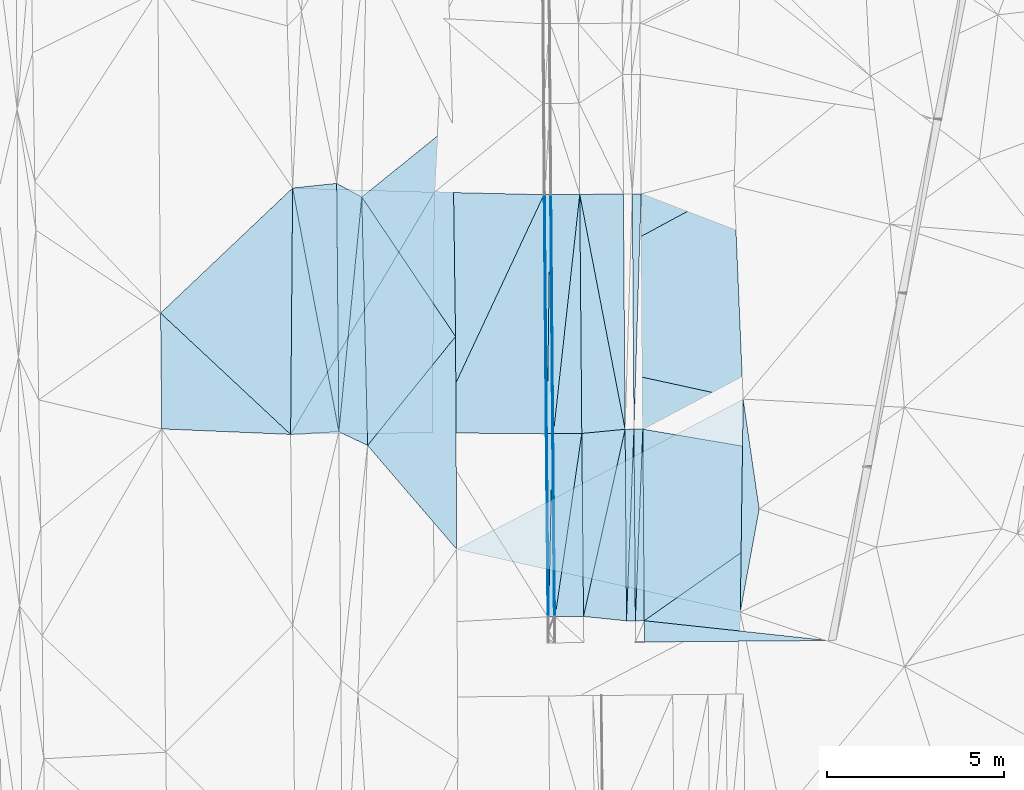
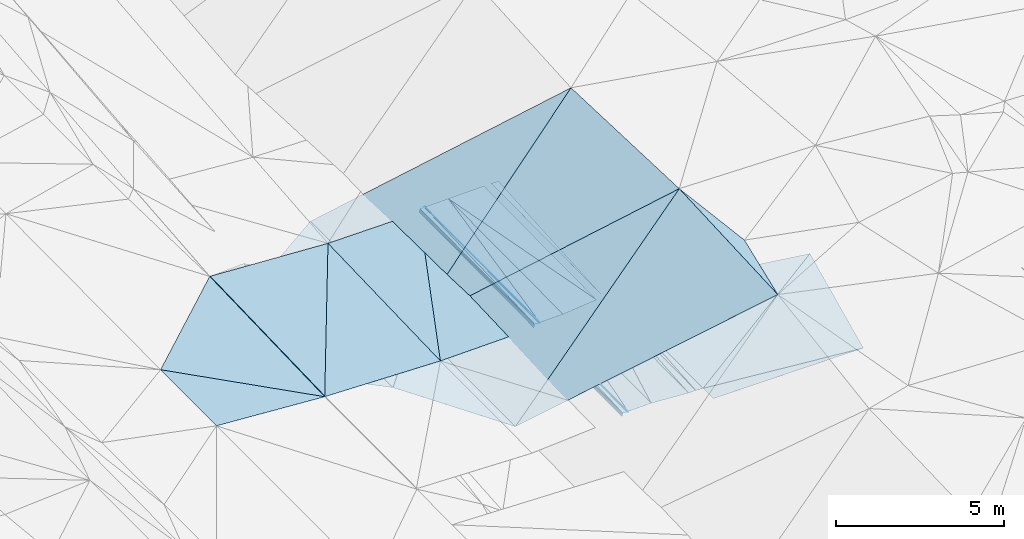
# One storey, part 37 of 275: 46 plates.
"""IFC2X3 building model written with IfcOpenShell, lengths in millimetres."""

from ifc_helpers import new_model, si_unit, frame, origin_with_axes, place, context, subcontext, project, spatial, polyline, outline, extrude, material, type_object, element, save


model = new_model("IFC2X3")

# Units and contexts
model_context = context("Model", 3, precision=1e-05, world=origin_with_axes())
body_context = subcontext(model_context, "Body", "Model", "MODEL_VIEW")
ifc_project = project(units=[si_unit("LENGTHUNIT", "METRE", prefix="MILLI"), si_unit("AREAUNIT", "SQUARE_METRE"), si_unit("VOLUMEUNIT", "CUBIC_METRE"), si_unit("MASSUNIT", "GRAM", prefix="KILO"), si_unit("TIMEUNIT", "SECOND"), si_unit("PLANEANGLEUNIT", "RADIAN"), si_unit("SOLIDANGLEUNIT", "STERADIAN"), si_unit("THERMODYNAMICTEMPERATUREUNIT", "DEGREE_CELSIUS"), si_unit("LUMINOUSINTENSITYUNIT", "LUMEN")], contexts=[model_context])

# Site, building, storey
site_placement = place(None, origin_with_axes())
site = spatial("IfcSite", under=ifc_project, at=site_placement, CompositionType="ELEMENT")
building_placement = place(site_placement, origin_with_axes())
building = spatial("IfcBuilding", under=site, at=building_placement, Name="Undefined", CompositionType="ELEMENT")
storey_placement = place(building_placement, origin_with_axes())
storey = spatial("IfcBuildingStorey", under=building, at=storey_placement, Name="Undefined", CompositionType="ELEMENT", Elevation=0.0)

# Plates
ifc_material = material()
plate_type_1 = type_object("IfcPlateType", PredefinedType="NOTDEFINED")
plate_1_placement = place(storey_placement, frame((-54895.4084070952, 29750.2640162456, 41944.5707269681), z_axis=(-0.0500723807362352, 0.0200544303251957, -0.998544228620714), x_axis=(-0.00717823700979567, 0.999765334400991, 0.0204389100371159)))
element("IfcPlate", 1, at=plate_1_placement, inside=storey, type_object=plate_type_1, material=ifc_material, Name="00_PR", context=body_context, shape_type="SweptSolid", body=[
    extrude(outline(polyline([(0.0, 0.0), (6633.6708984375, -2.11002770811319e-10), (6633.4150390625, 250.312622070313), (0.0, 0.0)])), frame((-8.85201319254618e-08, 2.18876761149539e-07, -0.5000001331573), z_axis=(0.0, 0.0, 1.0), x_axis=(1.0, 0.0, 0.0)), (0.0, 0.0, 1.0), 1.0),
])
plate_2_placement = place(storey_placement, frame((-54856.6384871649, 24350.4041556181, 41820.7377537856), z_axis=(-0.0500876728753474, 0.0225383897221612, -0.998490483687584), x_axis=(-0.00717772900254123, 0.999711397535793, 0.0229260080126891)))
element("IfcPlate", 2, at=plate_2_placement, inside=storey, type_object=plate_type_1, material=ifc_material, Name="00_PR", context=body_context, shape_type="SweptSolid", body=[
    extrude(outline(polyline([(0.0, 0.0), (5401.419921875, -5.98083715885878e-09), (5401.1328125, 250.311676025391), (0.0, 0.0)])), frame((-8.85201319254618e-08, 2.18876761149539e-07, -0.5000001331573), z_axis=(0.0, 0.0, 1.0), x_axis=(1.0, 0.0, 0.0)), (0.0, 0.0, 1.0), 1.0),
])
plate_3_placement = place(storey_placement, frame((-54645.4153229991, 29752.0595880414, 41932.0707538984), z_axis=(-0.0500876728753474, 0.0225383897221612, -0.998490483687584), x_axis=(0.00717789902175713, -0.999711396268906, -0.0229260100259001)))
element("IfcPlate", 3, at=plate_3_placement, inside=storey, type_object=plate_type_1, material=ifc_material, Name="00_PR", context=body_context, shape_type="SweptSolid", body=[
    extrude(outline(polyline([(0.0, 0.0), (5401.41943359375, -2.86672729998827e-09), (5401.1328125, 250.312591552734), (0.0, 0.0)])), frame((-8.85201319254618e-08, 2.18876761149539e-07, -0.5000001331573), z_axis=(0.0, 0.0, 1.0), x_axis=(1.0, 0.0, 0.0)), (0.0, 0.0, 1.0), 1.0),
])
plate_4_placement = place(storey_placement, frame((-54895.3734605082, 29750.2655212708, 41944.5702304905), z_axis=(0.0198256450246044, 0.0230643615691423, -0.99953738250491), x_axis=(0.00717789902175713, -0.999711396268906, -0.0229260100259001)))
element("IfcPlate", 4, at=plate_4_placement, inside=storey, type_object=plate_type_1, material=ifc_material, Name="00_PR", context=body_context, shape_type="SweptSolid", body=[
    extrude(outline(polyline([(0.0, 0.0), (5401.419921875, -5.98083715885878e-09), (5401.5341796875, 250.050415039063), (0.0, 0.0)])), frame((-8.85201319254618e-08, 2.18876761149539e-07, -0.5000001331573), z_axis=(0.0, 0.0, 1.0), x_axis=(1.0, 0.0, 0.0)), (0.0, 0.0, 1.0), 1.0),
])
plate_5_placement = place(storey_placement, frame((-55106.597538753, 24348.6096869643, 41815.7372321746), z_axis=(0.0198256450246044, 0.0230643615691423, -0.99953738250491), x_axis=(-0.00717772900254123, 0.999711397535793, 0.0229260080126891)))
element("IfcPlate", 5, at=plate_5_placement, inside=storey, type_object=plate_type_1, material=ifc_material, Name="00_PR", context=body_context, shape_type="SweptSolid", body=[
    extrude(outline(polyline([(0.0, 0.0), (5401.4189453125, 9.1313268058002e-09), (5401.53466796875, 250.050018310547), (0.0, 0.0)])), frame((-8.85201319254618e-08, 2.18876761149539e-07, -0.5000001331573), z_axis=(0.0, 0.0, 1.0), x_axis=(1.0, 0.0, 0.0)), (0.0, 0.0, 1.0), 1.0),
])
plate_type_2 = type_object("IfcPlateType", PredefinedType="NOTDEFINED")
plate_6_placement = place(storey_placement, frame((-54645.3903405653, 29752.0597822117, 41932.0701304337), z_axis=(-0.000129018325381022, 0.0229256746654247, -0.999737163856284), x_axis=(0.985830827411164, -0.167695548063093, -0.00397276800721903)))
element("IfcPlate", 6, at=plate_6_placement, inside=storey, type_object=plate_type_2, material=ifc_material, Name="00_PR", context=body_context, shape_type="SweptSolid", body=[
    extrude(outline(polyline([(0.0, 0.0), (6307.44091796875, 3.06681613437831e-09), (944.246032714844, 5318.2451171875), (0.0, 0.0)])), frame((-8.85201319254618e-08, 2.18876761149539e-07, -0.5000001331573), z_axis=(0.0, 0.0, 1.0), x_axis=(1.0, 0.0, 0.0)), (0.0, 0.0, 1.0), 1.0),
])
plate_type_3 = type_object("IfcPlateType", PredefinedType="NOTDEFINED")
plate_7_placement = place(storey_placement, frame((-54606.6195060492, 24352.1977344257, 41808.2371014104), z_axis=(-0.000145232154742154, 0.0202303364450008, -0.999795335253643), x_axis=(0.994251223321297, -0.107047497028802, -0.00231047700119528)))
element("IfcPlate", 7, at=plate_7_placement, inside=storey, type_object=plate_type_3, material=ifc_material, Name="00_PR", context=body_context, shape_type="SweptSolid", body=[
    extrude(outline(polyline([(0.0, 0.0), (5217.537109375, -5.2677933126688e-09), (68.5379028320313, 596.1962890625), (0.0, 0.0)])), frame((-8.85201319254618e-08, 2.18876761149539e-07, -0.5000001331573), z_axis=(0.0, 0.0, 1.0), x_axis=(1.0, 0.0, 0.0)), (0.0, 0.0, 1.0), 1.0),
])
plate_type_4 = type_object("IfcPlateType", PredefinedType="NOTDEFINED")
plate_8_placement = place(storey_placement, frame((-48427.3203026964, 28694.3298122455, 41907.0121263178), z_axis=(0.000108681248573426, 0.0225875796306291, -0.999744862169752), x_axis=(-0.198302551947202, -0.979890303884837, -0.0221605560334045)))
element("IfcPlate", 8, at=plate_8_placement, inside=storey, type_object=plate_type_4, material=ifc_material, Name="00_PR", context=body_context, shape_type="SweptSolid", body=[
    extrude(outline(polyline([(0.0, 0.0), (5001.228515625, -2.22644302994013e-09), (5482.37158203125, 5195.30517578125), (0.0, 0.0)])), frame((-8.85201319254618e-08, 2.18876761149539e-07, -0.5000001331573), z_axis=(0.0, 0.0, 1.0), x_axis=(1.0, 0.0, 0.0)), (0.0, 0.0, 1.0), 1.0),
])
plate_type_5 = type_object("IfcPlateType", PredefinedType="NOTDEFINED")
plate_9_placement = place(storey_placement, frame((-57433.1344544477, 36362.7875347337, 41914.3217369555), z_axis=(0.970054360845348, 0.0131957801587972, -0.242529190801695), x_axis=(0.242505601051944, 0.00338357902530367, 0.970144105198509)))
element("IfcPlate", 9, at=plate_9_placement, inside=storey, type_object=plate_type_5, material=ifc_material, Name="00_PR", context=body_context, shape_type="SweptSolid", body=[
    extrude(outline(polyline([(0.0, 0.0), (123.69295501709, -7.27595761418343e-11), (-18.7066040039063, 6740.505859375), (0.0, 0.0)])), frame((-8.85201319254618e-08, 2.18876761149539e-07, -0.5000001331573), z_axis=(0.0, 0.0, 1.0), x_axis=(1.0, 0.0, 0.0)), (0.0, 0.0, 1.0), 1.0),
])
plate_10_placement = place(storey_placement, frame((-57375.8022665797, 29621.3845984136, 41776.7278401148), z_axis=(0.970083354754348, 0.0147495674300355, -0.242323616449527), x_axis=(0.242164143968422, 0.0118048940212785, 0.970163476870361)))
element("IfcPlate", 10, at=plate_10_placement, inside=storey, type_object=plate_type_5, material=ifc_material, Name="00_PR", context=body_context, shape_type="SweptSolid", body=[
    extrude(outline(polyline([(0.0, 0.0), (123.690490722656, -1.12777343019843e-10), (-40.1428527832031, 5157.56005859375), (0.0, 0.0)])), frame((-8.85201319254618e-08, 2.18876761149539e-07, -0.5000001331573), z_axis=(0.0, 0.0, 1.0), x_axis=(1.0, 0.0, 0.0)), (0.0, 0.0, 1.0), 1.0),
])
plate_11_placement = place(storey_placement, frame((-57296.9675207864, 24464.2713309087, 41778.4242810916), z_axis=(0.970303119750049, 0.0147532161955438, -0.241441915199513), x_axis=(-0.241083956011316, -0.0225474160263247, -0.970242310036245)))
element("IfcPlate", 11, at=plate_11_placement, inside=storey, type_object=plate_type_5, material=ifc_material, Name="00_PR", context=body_context, shape_type="SweptSolid", body=[
    extrude(outline(polyline([(0.0, 0.0), (123.68147277832, 2.9831426218152e-10), (-95.6282806396484, 5156.82958984375), (0.0, 0.0)])), frame((-8.85201319254618e-08, 2.18876761149539e-07, -0.5000001331573), z_axis=(0.0, 0.0, 1.0), x_axis=(1.0, 0.0, 0.0)), (0.0, 0.0, 1.0), 1.0),
])
plate_12_placement = place(storey_placement, frame((-57345.8488538652, 29622.8439734198, 41896.7278483205), z_axis=(0.970108864343709, 0.0131959167882542, -0.24231107919754), x_axis=(-0.242164143958002, -0.0118048940251604, -0.970163476872915)))
element("IfcPlate", 12, at=plate_12_placement, inside=storey, type_object=plate_type_5, material=ifc_material, Name="00_PR", context=body_context, shape_type="SweptSolid", body=[
    extrude(outline(polyline([(0.0, 0.0), (123.690490722656, -1.12777343019843e-10), (-75.4959335327148, 6740.10888671875), (0.0, 0.0)])), frame((-8.85201319254618e-08, 2.18876761149539e-07, -0.5000001331573), z_axis=(0.0, 0.0, 1.0), x_axis=(1.0, 0.0, 0.0)), (0.0, 0.0, 1.0), 1.0),
])
plate_type_6 = type_object("IfcPlateType", PredefinedType="NOTDEFINED")
plate_13_placement = place(storey_placement, frame((-57253.6249709212, 36364.2197929239, 42033.9431076846), z_axis=(-0.000137433398031107, 0.0204080235845787, -0.99979172515351), x_axis=(-0.0137480829898779, -0.999697283477655, -0.0204042059757569)))
element("IfcPlate", 13, at=plate_13_placement, inside=storey, type_object=plate_type_6, material=ifc_material, Name="00_PR", context=body_context, shape_type="SweptSolid", body=[
    extrude(outline(polyline([(0.0, 0.0), (6743.41357421875, 1.33222783915699e-08), (3.07201170921326, 149.970291137695), (0.0, 0.0)])), frame((-8.85201319254618e-08, 2.18876761149539e-07, -0.5000001331573), z_axis=(0.0, 0.0, 1.0), x_axis=(1.0, 0.0, 0.0)), (0.0, 0.0, 1.0), 1.0),
])
plate_14_placement = place(storey_placement, frame((-57346.3339198748, 29622.8475791234, 41896.3491080499), z_axis=(-2.34314248828615e-05, 0.0204064566452411, -0.999791766308442), x_axis=(0.0137480829889003, 0.99969728347759, 0.0204042059796114)))
element("IfcPlate", 14, at=plate_14_placement, inside=storey, type_object=plate_type_6, material=ifc_material, Name="00_PR", context=body_context, shape_type="SweptSolid", body=[
    extrude(outline(polyline([(0.0, 0.0), (6743.41357421875, 1.33222783915699e-08), (2.23498868942261, 150.023101806641), (0.0, 0.0)])), frame((-8.85201319254618e-08, 2.18876761149539e-07, -0.5000001331573), z_axis=(0.0, 0.0, 1.0), x_axis=(1.0, 0.0, 0.0)), (0.0, 0.0, 1.0), 1.0),
])
plate_15_placement = place(storey_placement, frame((-57196.2942705991, 29623.0211226267, 41896.3491352206), z_axis=(-2.63265869253447e-05, 0.0229271942118745, -0.999737136987759), x_axis=(-0.019600190991622, -0.999545097466067, -0.0229222739849867)))
element("IfcPlate", 15, at=plate_15_placement, inside=storey, type_object=plate_type_6, material=ifc_material, Name="00_PR", context=body_context, shape_type="SweptSolid", body=[
    extrude(outline(polyline([(0.0, 0.0), (5161.09326171875, 2.97586666420102e-09), (3.1130108833313, 150.007446289063), (0.0, 0.0)])), frame((-8.85201319254618e-08, 2.18876761149539e-07, -0.5000001331573), z_axis=(0.0, 0.0, 1.0), x_axis=(1.0, 0.0, 0.0)), (0.0, 0.0, 1.0), 1.0),
])
plate_16_placement = place(storey_placement, frame((-57297.4525987376, 24464.2754148544, 41778.0451354272), z_axis=(0.00015291009529218, 0.0229236811287797, -0.999737206200714), x_axis=(0.0196001909899472, 0.999545097466061, 0.0229222739866883)))
element("IfcPlate", 16, at=plate_16_placement, inside=storey, type_object=plate_type_6, material=ifc_material, Name="00_PR", context=body_context, shape_type="SweptSolid", body=[
    extrude(outline(polyline([(0.0, 0.0), (5161.09326171875, 2.97586666420102e-09), (1.94216907024384, 150.164596557617), (0.0, 0.0)])), frame((-8.85201319254618e-08, 2.18876761149539e-07, -0.5000001331573), z_axis=(0.0, 0.0, 1.0), x_axis=(1.0, 0.0, 0.0)), (0.0, 0.0, 1.0), 1.0),
])
plate_type_7 = type_object("IfcPlateType", PredefinedType="NOTDEFINED")
plate_17_placement = place(storey_placement, frame((-57223.6165664526, 36364.4578675857, 42034.5432058121), z_axis=(0.0198296849093115, 0.0205713190816245, -0.999591718867078), x_axis=(0.00850252101753427, -0.99975562086186, -0.0204060209610408)))
element("IfcPlate", 17, at=plate_17_placement, inside=storey, type_object=plate_type_7, material=ifc_material, Name="00_PR", context=body_context, shape_type="SweptSolid", body=[
    extrude(outline(polyline([(0.0, 0.0), (6742.8134765625, -6.97764335200191e-09), (-0.00488473894074559, 30.0053634643555), (0.0, 0.0)])), frame((-8.85201319254618e-08, 2.18876761149539e-07, -0.5000001331573), z_axis=(0.0, 0.0, 1.0), x_axis=(1.0, 0.0, 0.0)), (0.0, 0.0, 1.0), 1.0),
])
plate_18_placement = place(storey_placement, frame((-57166.2856756733, 29623.293219365, 41896.949233173), z_axis=(0.0197821144921404, 0.0231056803227607, -0.999537290691569), x_axis=(0.00949658701787016, -0.999692166788818, -0.0229213109592606)))
element("IfcPlate", 18, at=plate_18_placement, inside=storey, type_object=plate_type_7, material=ifc_material, Name="00_PR", context=body_context, shape_type="SweptSolid", body=[
    extrude(outline(polyline([(0.0, 0.0), (5161.31005859375, 4.9622030928731e-09), (0.000789615500252694, 30.0059223175049), (0.0, 0.0)])), frame((-8.85201319254618e-08, 2.18876761149539e-07, -0.5000001331573), z_axis=(0.0, 0.0, 1.0), x_axis=(1.0, 0.0, 0.0)), (0.0, 0.0, 1.0), 1.0),
])
plate_19_placement = place(storey_placement, frame((-57196.2843567241, 29623.0199454779, 41896.3492073408), z_axis=(0.0198061943140049, 0.0205710242482274, -0.999592190659858), x_axis=(-0.00850252101929209, 0.999755620861784, 0.0204060209640744)))
element("IfcPlate", 19, at=plate_19_placement, inside=storey, type_object=plate_type_7, material=ifc_material, Name="00_PR", context=body_context, shape_type="SweptSolid", body=[
    extrude(outline(polyline([(0.0, 0.0), (6742.84765625, -3.44152795150876e-09), (0.0291208140552044, 30.0059070587158), (0.0, 0.0)])), frame((-8.85201319254618e-08, 2.18876761149539e-07, -0.5000001331573), z_axis=(0.0, 0.0, 1.0), x_axis=(1.0, 0.0, 0.0)), (0.0, 0.0, 1.0), 1.0),
])
plate_20_placement = place(storey_placement, frame((-57147.2689878061, 24463.2737848812, 41778.045234851), z_axis=(0.0197624718023815, 0.0231053889510078, -0.999537685987718), x_axis=(-0.00949658701778699, 0.999692166788749, 0.0229213109622704)))
element("IfcPlate", 20, at=plate_20_placement, inside=storey, type_object=plate_type_7, material=ifc_material, Name="00_PR", context=body_context, shape_type="SweptSolid", body=[
    extrude(outline(polyline([(0.0, 0.0), (5161.33642578125, 1.63709046319127e-09), (0.0267784167081118, 30.0055999755859), (0.0, 0.0)])), frame((-8.85201319254618e-08, 2.18876761149539e-07, -0.5000001331573), z_axis=(0.0, 0.0, 1.0), x_axis=(1.0, 0.0, 0.0)), (0.0, 0.0, 1.0), 1.0),
])
plate_type_8 = type_object("IfcPlateType", PredefinedType="NOTDEFINED")
plate_21_placement = place(storey_placement, frame((-60573.7713493108, 29647.2968692294, 41682.639325338), z_axis=(0.0294556231130584, 0.0206475851868098, -0.999352812320541), x_axis=(0.423373744889158, 0.905418206822488, 0.0311856199694956)))
element("IfcPlate", 21, at=plate_21_placement, inside=storey, type_object=plate_type_8, material=ifc_material, Name="00_PR", context=body_context, shape_type="SweptSolid", body=[
    extrude(outline(polyline([(0.0, 0.0), (7417.00830078125, -1.23982317745686e-08), (1333.20068359375, 2907.9248046875), (0.0, 0.0)])), frame((-8.85201319254618e-08, 2.18876761149539e-07, -0.5000001331573), z_axis=(0.0, 0.0, 1.0), x_axis=(1.0, 0.0, 0.0)), (0.0, 0.0, 1.0), 1.0),
])
plate_type_9 = type_object("IfcPlateType", PredefinedType="NOTDEFINED")
plate_22_placement = place(storey_placement, frame((-64574.2855848202, 29603.7668010769, 41809.5003620296), z_axis=(-0.0319130146527098, 0.0206323588611077, -0.999277671752753), x_axis=(0.510579763286938, 0.859829175420949, 0.00144721000004495)))
element("IfcPlate", 22, at=plate_22_placement, inside=storey, type_object=plate_type_9, material=ifc_material, Name="00_PR", context=body_context, shape_type="SweptSolid", body=[
    extrude(outline(polyline([(0.0, 0.0), (7942.87158203125, -3.24507709592581e-09), (2079.81079101563, 3419.97729492188), (0.0, 0.0)])), frame((-8.85201319254618e-08, 2.18876761149539e-07, -0.5000001331573), z_axis=(0.0, 0.0, 1.0), x_axis=(1.0, 0.0, 0.0)), (0.0, 0.0, 1.0), 1.0),
])
plate_type_10 = type_object("IfcPlateType", PredefinedType="NOTDEFINED")
plate_23_placement = place(storey_placement, frame((-60518.8159968476, 36433.279231441, 41820.9953535005), z_axis=(-0.0315165853109351, 0.0203969823452653, -0.999295085528567), x_axis=(-0.510579763289041, -0.859829175419697, -0.00144721000251744)))
element("IfcPlate", 23, at=plate_23_placement, inside=storey, type_object=plate_type_10, material=ifc_material, Name="00_PR", context=body_context, shape_type="SweptSolid", body=[
    extrude(outline(polyline([(0.0, 0.0), (7942.87158203125, -3.24507709592581e-09), (1941.65710449219, 3500.50390625), (0.0, 0.0)])), frame((-8.85201319254618e-08, 2.18876761149539e-07, -0.5000001331573), z_axis=(0.0, 0.0, 1.0), x_axis=(1.0, 0.0, 0.0)), (0.0, 0.0, 1.0), 1.0),
])
plate_type_11 = type_object("IfcPlateType", PredefinedType="NOTDEFINED")
plate_24_placement = place(storey_placement, frame((-55192.9846104297, 36380.5839446059, 42075.1552051376), z_axis=(0.019827502735749, 0.0205777131773347, -0.999591630545022), x_axis=(0.0071782370249891, -0.999765334401105, -0.0204389100262064)))
element("IfcPlate", 24, at=plate_24_placement, inside=storey, type_object=plate_type_11, material=ifc_material, Name="00_PR", context=body_context, shape_type="SweptSolid", body=[
    extrude(outline(polyline([(0.0, 0.0), (6633.671875, 2.05327523872256e-08), (1.43959248065948, 1230.94079589844), (0.0, 0.0)])), frame((-8.85201319254618e-08, 2.18876761149539e-07, -0.5000001331573), z_axis=(0.0, 0.0, 1.0), x_axis=(1.0, 0.0, 0.0)), (0.0, 0.0, 1.0), 1.0),
])
plate_type_12 = type_object("IfcPlateType", PredefinedType="NOTDEFINED")
plate_25_placement = place(storey_placement, frame((-55145.3670981211, 29748.4698762347, 41939.570231511), z_axis=(0.0197544585597547, 0.0230638855470726, -0.99953880292387), x_axis=(0.00717789902175713, -0.999711396268906, -0.0229260100259001)))
element("IfcPlate", 25, at=plate_25_placement, inside=storey, type_object=plate_type_12, material=ifc_material, Name="00_PR", context=body_context, shape_type="SweptSolid", body=[
    extrude(outline(polyline([(0.0, 0.0), (5401.4189453125, 9.1313268058002e-09), (5270.341796875, 1210.0390625), (0.0, 0.0)])), frame((-8.85201319254618e-08, 2.18876761149539e-07, -0.5000001331573), z_axis=(0.0, 0.0, 1.0), x_axis=(1.0, 0.0, 0.0)), (0.0, 0.0, 1.0), 1.0),
])
plate_type_13 = type_object("IfcPlateType", PredefinedType="NOTDEFINED")
plate_26_placement = place(storey_placement, frame((-56423.6413719435, 36370.8112537786, 42050.5432053524), z_axis=(0.0198060953423537, 0.0205738530104772, -0.999592134402624), x_axis=(0.00850248800260614, -0.999755565497945, -0.0204087469887167)))
element("IfcPlate", 26, at=plate_26_placement, inside=storey, type_object=plate_type_13, material=ifc_material, Name="00_PR", context=body_context, shape_type="SweptSolid", body=[
    extrude(outline(polyline([(0.0, 0.0), (6741.9130859375, 2.04454408958554e-09), (6742.6904296875, 800.159851074219), (0.0, 0.0)])), frame((-8.85201319254618e-08, 2.18876761149539e-07, -0.5000001331573), z_axis=(0.0, 0.0, 1.0), x_axis=(1.0, 0.0, 0.0)), (0.0, 0.0, 1.0), 1.0),
])
plate_27_placement = place(storey_placement, frame((-56366.318358162, 29630.5473365314, 41912.949232907), z_axis=(0.0197622458418474, 0.0231085657826838, -0.999537617014364), x_axis=(0.00949656499882243, -0.99969209669469, -0.0229243769686051)))
element("IfcPlate", 27, at=plate_27_placement, inside=storey, type_object=plate_type_13, material=ifc_material, Name="00_PR", context=body_context, shape_type="SweptSolid", body=[
    extrude(outline(polyline([(0.0, 0.0), (5160.6201171875, -3.58704710379243e-09), (5161.33203125, 800.159790039063), (0.0, 0.0)])), frame((-8.85201319254618e-08, 2.18876761149539e-07, -0.5000001331573), z_axis=(0.0, 0.0, 1.0), x_axis=(1.0, 0.0, 0.0)), (0.0, 0.0, 1.0), 1.0),
])
plate_28_placement = place(storey_placement, frame((-57166.2856519693, 29623.2919521182, 41896.9492060201), z_axis=(0.0198296849093115, 0.0205713190816245, -0.999591718867078), x_axis=(-0.00850252101929209, 0.999755620861784, 0.0204060209640744)))
element("IfcPlate", 28, at=plate_28_placement, inside=storey, type_object=plate_type_13, material=ifc_material, Name="00_PR", context=body_context, shape_type="SweptSolid", body=[
    extrude(outline(polyline([(0.0, 0.0), (6742.8134765625, -6.97764335200191e-09), (6742.6904296875, 800.160400390625), (0.0, 0.0)])), frame((-8.85201319254618e-08, 2.18876761149539e-07, -0.5000001331573), z_axis=(0.0, 0.0, 1.0), x_axis=(1.0, 0.0, 0.0)), (0.0, 0.0, 1.0), 1.0),
])
plate_29_placement = place(storey_placement, frame((-57117.2708424667, 24463.5717848462, 41778.6452333011), z_axis=(0.0197821144921404, 0.0231056803227607, -0.999537290691569), x_axis=(-0.00949658701778699, 0.999692166788749, 0.0229213109622704)))
element("IfcPlate", 29, at=plate_29_placement, inside=storey, type_object=plate_type_13, material=ifc_material, Name="00_PR", context=body_context, shape_type="SweptSolid", body=[
    extrude(outline(polyline([(0.0, 0.0), (5161.31005859375, 4.9622030928731e-09), (5161.33203125, 800.160217285156), (0.0, 0.0)])), frame((-8.85201319254618e-08, 2.18876761149539e-07, -0.5000001331573), z_axis=(0.0, 0.0, 1.0), x_axis=(1.0, 0.0, 0.0)), (0.0, 0.0, 1.0), 1.0),
])
plate_type_14 = type_object("IfcPlateType", PredefinedType="NOTDEFINED")
plate_30_placement = place(storey_placement, frame((-56366.3183356965, 29630.5460691692, 41912.9492055878), z_axis=(0.0198075215973235, 0.0205738645548118, -0.999592105903929), x_axis=(-0.00850248800490916, 0.999755565498, 0.0204087469850903)))
element("IfcPlate", 30, at=plate_30_placement, inside=storey, type_object=plate_type_14, material=ifc_material, Name="00_PR", context=body_context, shape_type="SweptSolid", body=[
    extrude(outline(polyline([(0.0, 0.0), (6741.9130859375, 2.04454408958554e-09), (108.05591583252, 1222.15393066406), (0.0, 0.0)])), frame((-8.85201319254618e-08, 2.18876761149539e-07, -0.5000001331573), z_axis=(0.0, 0.0, 1.0), x_axis=(1.0, 0.0, 0.0)), (0.0, 0.0, 1.0), 1.0),
])
plate_type_15 = type_object("IfcPlateType", PredefinedType="NOTDEFINED")
plate_31_placement = place(storey_placement, frame((-56317.3102920617, 24471.5161477881, 41794.6452307876), z_axis=(0.0195617873476278, 0.0231067529108341, -0.999541602158551), x_axis=(-0.00949656499819359, 0.999692096694775, 0.0229243769651296)))
element("IfcPlate", 31, at=plate_31_placement, inside=storey, type_object=plate_type_15, material=ifc_material, Name="00_PR", context=body_context, shape_type="SweptSolid", body=[
    extrude(outline(polyline([(0.0, 0.0), (5160.6201171875, -3.58704710379243e-09), (5267.52197265625, 1222.25549316406), (0.0, 0.0)])), frame((-8.85201319254618e-08, 2.18876761149539e-07, -0.5000001331573), z_axis=(0.0, 0.0, 1.0), x_axis=(1.0, 0.0, 0.0)), (0.0, 0.0, 1.0), 1.0),
])
plate_type_16 = type_object("IfcPlateType", PredefinedType="NOTDEFINED")
plate_32_placement = place(storey_placement, frame((-57433.6041983802, 36362.7910009887, 41913.9433365491), z_axis=(0.0305669138235757, 0.0201271605159665, -0.999330056182074), x_axis=(-0.423373744903151, -0.905418206850314, -0.0311856189716123)))
element("IfcPlate", 32, at=plate_32_placement, inside=storey, type_object=plate_type_16, material=ifc_material, Name="00_PR", context=body_context, shape_type="SweptSolid", body=[
    extrude(outline(polyline([(0.0, 0.0), (7417.00830078125, -1.23982317745686e-08), (1245.26196289063, 2825.1142578125), (0.0, 0.0)])), frame((-8.85201319254618e-08, 2.18876761149539e-07, -0.5000001331573), z_axis=(0.0, 0.0, 1.0), x_axis=(1.0, 0.0, 0.0)), (0.0, 0.0, 1.0), 1.0),
])
plate_type_17 = type_object("IfcPlateType", PredefinedType="NOTDEFINED")
plate_33_placement = place(storey_placement, frame((-51898.4024897921, 24594.4398376857, 44120.5035362828), z_axis=(-0.114787666962505, 0.0309803187056542, -0.9929068492896), x_axis=(0.0134066323516429, 0.999470868069656, 0.029635217041154)))
element("IfcPlate", 33, at=plate_33_placement, inside=storey, type_object=plate_type_17, material=ifc_material, Name="00", context=body_context, shape_type="SweptSolid", body=[
    extrude(outline(polyline([(0.0, 0.0), (6006.3671875, 5.26051735505462e-09), (2911.04443359375, 497.379730224609), (0.0, 0.0)])), frame((-8.85201319254618e-08, 2.18876761149539e-07, -0.5000001331573), z_axis=(0.0, 0.0, 1.0), x_axis=(1.0, 0.0, 0.0)), (0.0, 0.0, 1.0), 1.0),
])
plate_type_18 = type_object("IfcPlateType", PredefinedType="NOTDEFINED")
plate_34_placement = place(storey_placement, frame((-63213.772481078, 29679.3772558111, 41764.513744858), z_axis=(-0.232296113468906, 0.0173904518013238, -0.972489633802534), x_axis=(-0.0088541374933108, 0.999760911659468, 0.0199930929842949)))
element("IfcPlate", 34, at=plate_34_placement, inside=storey, type_object=plate_type_18, material=ifc_material, Name="00", context=body_context, shape_type="SweptSolid", body=[
    extrude(outline(polyline([(0.0, 0.0), (7002.41796875, -6.66477717459202e-09), (6605.90869140625, 724.180297851563), (0.0, 0.0)])), frame((-8.85201319254618e-08, 2.18876761149539e-07, -0.5000001331573), z_axis=(0.0, 0.0, 1.0), x_axis=(1.0, 0.0, 0.0)), (0.0, 0.0, 1.0), 1.0),
])
plate_type_19 = type_object("IfcPlateType", PredefinedType="NOTDEFINED")
plate_35_placement = place(storey_placement, frame((-59924.4650161632, 32362.3789614874, 41130.5362433382), z_axis=(0.372835690124525, 0.0272297145207694, -0.927497757849843), x_axis=(-0.0137496555623442, 0.9996217043267, 0.0238200590028775)))
element("IfcPlate", 35, at=plate_35_placement, inside=storey, type_object=plate_type_19, material=ifc_material, Name="00", context=body_context, shape_type="SweptSolid", body=[
    extrude(outline(polyline([(0.0, 0.0), (6003.34375, -3.39059624820948e-09), (4207.67578125, 8525.962890625), (0.0, 0.0)])), frame((-8.85201319254618e-08, 2.18876761149539e-07, -0.5000001331573), z_axis=(0.0, 0.0, 1.0), x_axis=(1.0, 0.0, 0.0)), (0.0, 0.0, 1.0), 1.0),
])
plate_type_20 = type_object("IfcPlateType", PredefinedType="NOTDEFINED")
plate_36_placement = place(storey_placement, frame((-62567.9179674236, 36293.3050445465, 41728.5130669872), z_axis=(-0.226557531196561, 0.0168226604904226, -0.973852495582438), x_axis=(0.0233621655435943, -0.999469315164357, -0.0227001600435862)))
element("IfcPlate", 36, at=plate_36_placement, inside=storey, type_object=plate_type_20, material=ifc_material, Name="00", context=body_context, shape_type="SweptSolid", body=[
    extrude(outline(polyline([(0.0, 0.0), (7004.35595703125, 3.11410985887051e-09), (6594.5126953125, 821.5048828125), (0.0, 0.0)])), frame((-8.85201319254618e-08, 2.18876761149539e-07, -0.5000001331573), z_axis=(0.0, 0.0, 1.0), x_axis=(1.0, 0.0, 0.0)), (0.0, 0.0, 1.0), 1.0),
])
plate_type_21 = type_object("IfcPlateType", PredefinedType="NOTDEFINED")
plate_37_placement = place(storey_placement, frame((-60007.2909177041, 38363.4482532324, 41273.5093221384), z_axis=(-0.191155981866452, 0.0207551044603268, -0.981340214316887), x_axis=(0.0137496555616393, -0.999621704326797, -0.0238200589992076)))
element("IfcPlate", 37, at=plate_37_placement, inside=storey, type_object=plate_type_21, material=ifc_material, Name="00", context=body_context, shape_type="SweptSolid", body=[
    extrude(outline(polyline([(0.0, 0.0), (6003.34375, -3.39059624820948e-09), (2023.3125, 2637.31616210938), (0.0, 0.0)])), frame((-8.85201319254618e-08, 2.18876761149539e-07, -0.5000001331573), z_axis=(0.0, 0.0, 1.0), x_axis=(1.0, 0.0, 0.0)), (0.0, 0.0, 1.0), 1.0),
])
plate_type_22 = type_object("IfcPlateType", PredefinedType="NOTDEFINED")
plate_38_placement = place(storey_placement, frame((-68240.0858667427, 33023.5491804737, 41999.5003570351), z_axis=(-0.032113333044828, 0.0210945146330983, -0.999261605033009), x_axis=(0.73069297742833, -0.681654952569259, -0.037872131900954)))
element("IfcPlate", 38, at=plate_38_placement, inside=storey, type_object=plate_type_22, material=ifc_material, Name="00", context=body_context, shape_type="SweptSolid", body=[
    extrude(outline(polyline([(0.0, 0.0), (5016.88134765625, 5.84259396418929e-09), (2252.7939453125, 2365.14697265625), (0.0, 0.0)])), frame((-8.85201319254618e-08, 2.18876761149539e-07, -0.5000001331573), z_axis=(0.0, 0.0, 1.0), x_axis=(1.0, 0.0, 0.0)), (0.0, 0.0, 1.0), 1.0),
])
plate_type_23 = type_object("IfcPlateType", PredefinedType="NOTDEFINED")
plate_39_placement = place(storey_placement, frame((-62567.9024480432, 36293.3054833461, 41728.5097229522), z_axis=(-0.195518473074691, 0.017700079356071, -0.9805402765197), x_axis=(0.553595079682288, -0.823313675015829, -0.125248074969202)))
element("IfcPlate", 39, at=plate_39_placement, inside=storey, type_object=plate_type_23, material=ifc_material, Name="00", context=body_context, shape_type="SweptSolid", body=[
    extrude(outline(polyline([(0.0, 0.0), (4774.5244140625, -2.83762346953154e-10), (5874.224609375, 3815.0341796875), (0.0, 0.0)])), frame((-8.85201319254618e-08, 2.18876761149539e-07, -0.5000001331573), z_axis=(0.0, 0.0, 1.0), x_axis=(1.0, 0.0, 0.0)), (0.0, 0.0, 1.0), 1.0),
])
plate_type_24 = type_object("IfcPlateType", PredefinedType="NOTDEFINED")
plate_40_placement = place(storey_placement, frame((-64518.0073399526, 36549.6523368873, 41949.5004542252), z_axis=(-0.0382513769033427, 0.0196406145129394, -0.999075111503911), x_axis=(0.993885881095871, 0.104378165551919, -0.0360007488019535)))
element("IfcPlate", 40, at=plate_40_placement, inside=storey, type_object=plate_type_24, material=ifc_material, Name="00", context=body_context, shape_type="SweptSolid", body=[
    extrude(outline(polyline([(0.0, 0.0), (1249.97399902344, -1.09139364212751e-09), (585.910583496094, 6970.859375), (0.0, 0.0)])), frame((-8.85201319254618e-08, 2.18876761149539e-07, -0.5000001331573), z_axis=(0.0, 0.0, 1.0), x_axis=(1.0, 0.0, 0.0)), (0.0, 0.0, 1.0), 1.0),
])
plate_type_25 = type_object("IfcPlateType", PredefinedType="NOTDEFINED")
plate_41_placement = place(storey_placement, frame((-63213.6734161029, 29679.3787625358, 41764.5003879549), z_axis=(-0.0341816967635243, 0.0204168035910726, -0.999207068498562), x_axis=(-0.997915488761257, -0.0554561845190906, 0.0330043768152871)))
element("IfcPlate", 41, at=plate_41_placement, inside=storey, type_object=plate_type_25, material=ifc_material, Name="00", context=body_context, shape_type="SweptSolid", body=[
    extrude(outline(polyline([(0.0, 0.0), (1363.45556640625, -3.04862624034286e-09), (926.719604492188, 6933.7841796875), (0.0, 0.0)])), frame((-8.85201319254618e-08, 2.18876761149539e-07, -0.5000001331573), z_axis=(0.0, 0.0, 1.0), x_axis=(1.0, 0.0, 0.0)), (0.0, 0.0, 1.0), 1.0),
])
plate_type_26 = type_object("IfcPlateType", PredefinedType="NOTDEFINED")
plate_42_placement = place(storey_placement, frame((-64518.0045877333, 36549.6527186737, 41949.5003633032), z_axis=(-0.0327551052870301, 0.0204062114104521, -0.999255067344423), x_axis=(-0.00810094444361597, -0.999764126881034, -0.0201510620296958)))
element("IfcPlate", 42, at=plate_42_placement, inside=storey, type_object=plate_type_26, material=ifc_material, Name="00", context=body_context, shape_type="SweptSolid", body=[
    extrude(outline(polyline([(0.0, 0.0), (6947.52490234375, -1.17142917588353e-08), (3554.4169921875, 3695.3916015625), (0.0, 0.0)])), frame((-8.85201319254618e-08, 2.18876761149539e-07, -0.5000001331573), z_axis=(0.0, 0.0, 1.0), x_axis=(1.0, 0.0, 0.0)), (0.0, 0.0, 1.0), 1.0),
])
plate_type_27 = type_object("IfcPlateType", PredefinedType="NOTDEFINED")
plate_43_placement = place(storey_placement, frame((-59924.7461383784, 32362.3716399633, 41130.509081883), z_axis=(-0.189414600844779, 0.0125872403167288, -0.981816515632133), x_axis=(0.00528217149556032, -0.999890298151527, -0.0138380029896693)))
element("IfcPlate", 43, at=plate_43_placement, inside=storey, type_object=plate_type_27, material=ifc_material, Name="00", context=body_context, shape_type="SweptSolid", body=[
    extrude(outline(polyline([(0.0, 0.0), (5997.9755859375, 1.73167791217566e-09), (3050.19873046875, 2541.67553710938), (0.0, 0.0)])), frame((-8.85201319254618e-08, 2.18876761149539e-07, -0.5000001331573), z_axis=(0.0, 0.0, 1.0), x_axis=(1.0, 0.0, 0.0)), (0.0, 0.0, 1.0), 1.0),
])
plate_type_28 = type_object("IfcPlateType", PredefinedType="NOTDEFINED")
plate_44_placement = place(storey_placement, frame((-59892.7857277048, 26365.0553304786, 41047.5348877972), z_axis=(0.366732478170775, 0.0148109972018887, -0.930208537811069), x_axis=(-0.00528217156019506, 0.99989029815097, 0.0138380030052257)))
element("IfcPlate", 44, at=plate_44_placement, inside=storey, type_object=plate_type_28, material=ifc_material, Name="00", context=body_context, shape_type="SweptSolid", body=[
    extrude(outline(polyline([(0.0, 0.0), (5997.9755859375, 1.73167791217566e-09), (4234.4345703125, 8704.091796875), (0.0, 0.0)])), frame((-8.85201319254618e-08, 2.18876761149539e-07, -0.5000001331573), z_axis=(0.0, 0.0, 1.0), x_axis=(1.0, 0.0, 0.0)), (0.0, 0.0, 1.0), 1.0),
])
plate_type_29 = type_object("IfcPlateType", PredefinedType="NOTDEFINED")
plate_45_placement = place(storey_placement, frame((-51817.6384415736, 30597.6249319962, 44298.5342545751), z_axis=(0.36308330506432, 0.0227488930447977, -0.931478932369813), x_axis=(-0.013406632439482, -0.999470868069593, -0.0296352170035516)))
element("IfcPlate", 45, at=plate_45_placement, inside=storey, type_object=plate_type_29, material=ifc_material, Name="00", context=body_context, shape_type="SweptSolid", body=[
    extrude(outline(polyline([(0.0, 0.0), (6006.3671875, 5.26051735505462e-09), (4434.9306640625, 8603.6640625), (0.0, 0.0)])), frame((-8.85201319254618e-08, 2.18876761149539e-07, -0.5000001331573), z_axis=(0.0, 0.0, 1.0), x_axis=(1.0, 0.0, 0.0)), (0.0, 0.0, 1.0), 1.0),
])
plate_type_30 = type_object("IfcPlateType", PredefinedType="NOTDEFINED")
plate_46_placement = place(storey_placement, frame((-52071.9703302751, 36601.4767760836, 44411.5357796211), z_axis=(0.370028947322828, 0.0331493941357915, -0.928428616432944), x_axis=(0.04231662756033, -0.998927335945158, -0.0188010779858613)))
element("IfcPlate", 46, at=plate_46_placement, inside=storey, type_object=plate_type_30, material=ifc_material, Name="00", context=body_context, shape_type="SweptSolid", body=[
    extrude(outline(polyline([(0.0, 0.0), (6010.29345703125, -4.14729584008455e-09), (3963.94287109375, 8641.9755859375), (0.0, 0.0)])), frame((-8.85201319254618e-08, 2.18876761149539e-07, -0.5000001331573), z_axis=(0.0, 0.0, 1.0), x_axis=(1.0, 0.0, 0.0)), (0.0, 0.0, 1.0), 1.0),
])

save(model, "model.ifc")
